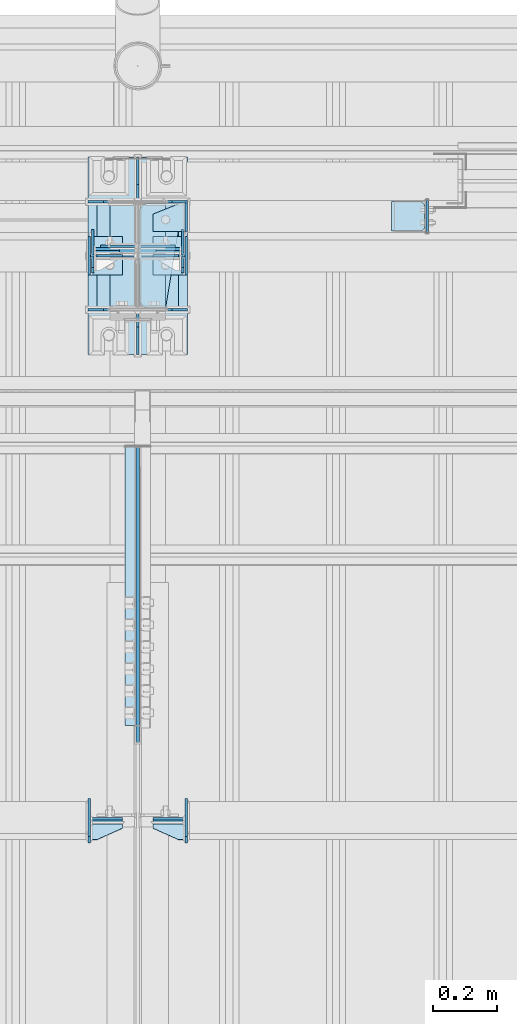
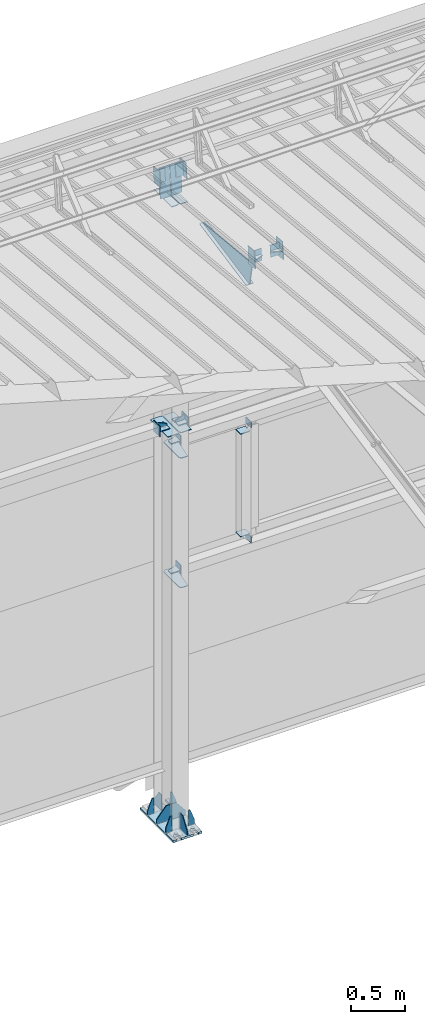
# One storey, part 138 of 709: 43 plates, 4 openings, 11 elements without a shape of their own.
"""IFC4 building model written with IfcOpenShell, lengths in millimetres."""

import ifcopenshell
import ifcopenshell.guid

model = None  # the IFC model being written
_history = None  # IfcOwnerHistory: only IFC2X3 demands one
_inside = {}  # id of a spatial element -> (the spatial element, [elements in it])
_under = {}  # id of a project, library or spatial element -> (it, [spatial elements below it])
_declared = {}  # id of a project -> (the project, [libraries it declares])
_typed = {}  # id of a type object -> (the type object, [elements of that type])
_made_of = {}  # id of a material, layer set ... -> (it, [elements and type objects made of it])


def new_model(schema):
    """Start an empty IFC model of exactly this schema.

    Asked for "IFC4X3", IfcOpenShell would pick the latest addendum, in which some entities
    have other attributes; the version numbers below select the first issue.
    IFC2X3 requires an IfcOwnerHistory on every rooted entity: one is made here for all.
    """
    global model, _history
    if schema == "IFC4X3":
        model = ifcopenshell.file(schema_version=(4, 3, 0, 0))
    else:
        model = ifcopenshell.file(schema=schema)
    _inside.clear()
    _under.clear()
    _declared.clear()
    _typed.clear()
    _made_of.clear()
    _history = None
    if model.schema == "IFC2X3":
        org = make("IfcOrganization", Name="unknown")
        user = make(
            "IfcPersonAndOrganization",
            ThePerson=make("IfcPerson", FamilyName="unknown"),
            TheOrganization=org,
        )
        app = make(
            "IfcApplication",
            ApplicationDeveloper=org,
            Version="unknown",
            ApplicationFullName="unknown",
            ApplicationIdentifier="unknown",
        )
        _history = make(
            "IfcOwnerHistory",
            OwningUser=user,
            OwningApplication=app,
            ChangeAction="ADDED",
            CreationDate=0,
        )
    return model


def make(cls, **values):
    """One entity of the class cls with the attributes given. An attribute that is None is left unset."""
    return model.create_entity(
        cls, **{name: value for name, value in values.items() if value is not None}
    )


def rooted(cls, **values):
    """An entity with a GlobalId (a new one), such as an element, a storey or a relation."""
    return make(cls, GlobalId=ifcopenshell.guid.new(), OwnerHistory=_history, **values)


def si_unit(unit_type, name, prefix=None):
    """IfcSIUnit, for example si_unit("LENGTHUNIT", "METRE", prefix="MILLI")."""
    return make("IfcSIUnit", UnitType=unit_type, Prefix=prefix, Name=name)


def assignment(units):
    """IfcUnitAssignment: the units of a project."""
    return None if units is None else make("IfcUnitAssignment", Units=units)


def point(xyz):
    """IfcCartesianPoint."""
    return None if xyz is None else make("IfcCartesianPoint", Coordinates=xyz)


def direction(xyz):
    """IfcDirection."""
    return None if xyz is None else make("IfcDirection", DirectionRatios=xyz)


def frame(location, z_axis=None, x_axis=None):
    """IfcAxis2Placement3D, a coordinate frame: its origin and axes. An axis left out is left unset."""
    return make(
        "IfcAxis2Placement3D",
        Location=point(location),
        Axis=direction(z_axis),
        RefDirection=direction(x_axis),
    )


def origin_with_axes():
    """The frame at (0, 0, 0) with the z axis (0, 0, 1) and the x axis (1, 0, 0) written out."""
    return frame((0.0, 0.0, 0.0), z_axis=(0.0, 0.0, 1.0), x_axis=(1.0, 0.0, 0.0))


def place(relative_to, where):
    """IfcLocalPlacement: puts the frame where relative to a parent placement (None: the world)."""
    return make(
        "IfcLocalPlacement", PlacementRelTo=relative_to, RelativePlacement=where
    )


def context(
    kind, dimensions, precision=None, world=None, true_north=None, identifier=None
):
    """IfcGeometricRepresentationContext, for example the 3D "Model" context."""
    return make(
        "IfcGeometricRepresentationContext",
        ContextIdentifier=identifier,
        ContextType=kind,
        CoordinateSpaceDimension=dimensions,
        Precision=precision,
        WorldCoordinateSystem=world,
        TrueNorth=true_north,
    )


def subcontext(parent, identifier, kind, view, scale=None):
    """IfcGeometricRepresentationSubContext, for example "Body" below "Model"."""
    return make(
        "IfcGeometricRepresentationSubContext",
        ContextIdentifier=identifier,
        ContextType=kind,
        ParentContext=parent,
        TargetScale=scale,
        TargetView=view,
    )


def project(units=None, contexts=None):
    """IfcProject with its units and contexts."""
    return rooted(
        "IfcProject",
        Name="project",
        RepresentationContexts=contexts,
        UnitsInContext=assignment(units),
    )


def spatial(cls, under=None, at=None, **own):
    """A site, building, storey or space (cls), placed at a placement, below another one or the project."""
    s = rooted(cls, ObjectPlacement=at, **own)
    if under is not None:
        _under.setdefault(under.id(), (under, []))[1].append(s)
    return s


def point_list(points):
    """IfcCartesianPointList2D or 3D."""
    cls = (
        "IfcCartesianPointList2D" if len(points[0]) == 2 else "IfcCartesianPointList3D"
    )
    return make(cls, CoordList=points)


def line(*indices):
    """IfcLineIndex: a straight run through numbered points of an indexed curve."""
    return model.create_entity("IfcLineIndex", indices)


def arc(*indices):
    """IfcArcIndex: an arc through three numbered points of an indexed curve."""
    return model.create_entity("IfcArcIndex", indices)


def indexed_curve(points, segments=None, self_intersect=None):
    """IfcIndexedPolyCurve: lines and arcs through numbered points (the first is 1)."""
    return make(
        "IfcIndexedPolyCurve",
        Points=point_list(points),
        Segments=segments,
        SelfIntersect=self_intersect,
    )


def outline(outer, holes=None, kind="AREA"):
    """IfcArbitraryClosedProfileDef: a profile drawn as a closed curve; with holes, ...WithVoids."""
    if holes is None:
        return make("IfcArbitraryClosedProfileDef", ProfileType=kind, OuterCurve=outer)
    return make(
        "IfcArbitraryProfileDefWithVoids",
        ProfileType=kind,
        OuterCurve=outer,
        InnerCurves=holes,
    )


def extrude(swept, where, along, depth):
    """IfcExtrudedAreaSolid: the profile swept, set in the frame where, extruded along a direction by depth."""
    return make(
        "IfcExtrudedAreaSolid",
        SweptArea=swept,
        Position=where,
        ExtrudedDirection=direction(along),
        Depth=depth,
    )


def shape(context_of_items, identifier, shape_type, items):
    """IfcShapeRepresentation: the items that make up one representation, for example the "Body"."""
    return make(
        "IfcShapeRepresentation",
        ContextOfItems=context_of_items,
        RepresentationIdentifier=identifier,
        RepresentationType=shape_type,
        Items=items,
    )


def material(Name=None, Category=None):
    """IfcMaterial."""
    return make("IfcMaterial", Name=Name, Category=Category)


def made_of(thing, what):
    """Note that an element or type object is made of a material, layer set ...; save() writes the relation."""
    if what is not None:
        _made_of.setdefault(what.id(), (what, []))[1].append(thing)
    return thing


def element(
    cls,
    number,
    at=None,
    inside=None,
    cuts=None,
    type_object=None,
    material=None,
    context=None,
    identifier="Body",
    shape_type=None,
    held_by="IfcProductDefinitionShape",
    body=None,
    shapes=None,
    **own,
):
    """One element of the class cls, such as IfcWall. Its Tag is "e" and its number.

    at: its placement. inside: the storey or other place that contains it. cuts: it is an
    opening in that element (IfcRelVoidsElement). A single representation is given by context,
    identifier, shape_type and body (its items); several are given by shapes. held_by: the class
    of the entity that holds the representations. save() writes the other relations.
    """
    e = rooted(cls, Tag="e%d" % number, ObjectPlacement=at, **own)
    if body is not None:
        shapes = [shape(context, identifier, shape_type, body)]
    if shapes is not None:
        e.Representation = make(held_by, Representations=shapes)
    if inside is not None:
        _inside.setdefault(inside.id(), (inside, []))[1].append(e)
    if cuts is not None:
        rooted(
            "IfcRelVoidsElement", RelatingBuildingElement=cuts, RelatedOpeningElement=e
        )
    if type_object is not None:
        _typed.setdefault(type_object.id(), (type_object, []))[1].append(e)
    return made_of(e, material)


def aggregate(whole, parts):
    """IfcRelAggregates: a whole, such as a stair, and the parts it consists of."""
    return rooted("IfcRelAggregates", RelatingObject=whole, RelatedObjects=parts)


def save(model, path):
    """Write the relations noted so far, then the file.

    IfcRelAggregates (storeys below a building ...), IfcRelContainedInSpatialStructure (elements
    in a storey), IfcRelDefinesByType, IfcRelAssociatesMaterial and IfcRelDeclares: one each for
    every whole, place, type object, material and project.
    """
    for whole, parts in _under.values():
        aggregate(whole, parts)
    for where, things in _inside.values():
        rooted(
            "IfcRelContainedInSpatialStructure",
            RelatedElements=things,
            RelatingStructure=where,
        )
    for kind, things in _typed.values():
        rooted("IfcRelDefinesByType", RelatedObjects=things, RelatingType=kind)
    for what, things in _made_of.values():
        rooted("IfcRelAssociatesMaterial", RelatedObjects=things, RelatingMaterial=what)
    for by, libraries in _declared.values():
        rooted("IfcRelDeclares", RelatingContext=by, RelatedDefinitions=libraries)
    model.write(path)


model = new_model("IFC4")

# Units and contexts
model_context = context("Model", 3, precision=0.2, world=origin_with_axes(), true_north=direction((0.0, 1.0)))
body_context = subcontext(model_context, "Body", "Model", "MODEL_VIEW")
ifc_project = project(units=[si_unit("LENGTHUNIT", "METRE", prefix="MILLI"), si_unit("AREAUNIT", "SQUARE_METRE"), si_unit("VOLUMEUNIT", "CUBIC_METRE"), si_unit("MASSUNIT", "GRAM", prefix="KILO"), si_unit("TIMEUNIT", "SECOND"), si_unit("PLANEANGLEUNIT", "RADIAN"), si_unit("SOLIDANGLEUNIT", "STERADIAN"), si_unit("THERMODYNAMICTEMPERATUREUNIT", "DEGREE_CELSIUS"), si_unit("LUMINOUSINTENSITYUNIT", "LUMEN")], contexts=[model_context])

# Site, building, storey
site_placement = place(None, origin_with_axes())
site = spatial("IfcSite", under=ifc_project, at=site_placement, CompositionType="ELEMENT")
building_placement = place(site_placement, origin_with_axes())
building = spatial("IfcBuilding", under=site, at=building_placement, Name="Undefined", CompositionType="ELEMENT")
storey_placement = place(building_placement, origin_with_axes())
storey = spatial("IfcBuildingStorey", under=building, at=storey_placement, Name="Undefined", CompositionType="ELEMENT", Elevation=0.0)

# Assembly, plates, voiding features
assembly_1_placement = place(storey_placement, frame((16000.0, 21827.0, -200.0), z_axis=(-1.0, 0.0, 0.0), x_axis=(0.0, 0.0, 1.0)))
assembly_1 = element("IfcElementAssembly", 1, at=assembly_1_placement, inside=storey)
ifc_material = material(Name="C355-6", Category="STEEL")
plate_1_placement = place(assembly_1_placement, frame((7434.21546, 30.02526, 3.0), z_axis=(0.099503719, -0.9950371902, 0.0), x_axis=(0.0, 0.0, 1.0)))
plate_1 = element("IfcPlate", 2, at=plate_1_placement, material=ifc_material, ObjectType="595", context=body_context, shape_type="SolidModel", body=[
    extrude(outline(indexed_curve([(0.0, 0.0), (114.0, 0.0), (114.0, 332.53554), (0.0, 332.53554)], segments=[line(1, 2, 3, 4, 1)])), frame((0.0, 0.0, 4.0), z_axis=(0.0, 0.0, 1.0), x_axis=(1.0, 0.0, 0.0)), (0.0, 0.0, -1.0), 8.0),
])
plate_2_placement = place(assembly_1_placement, frame((7097.93718, 163.0, 87.0), z_axis=(-1.0, 0.0, 0.0), x_axis=(0.0, 0.0, -1.0)))
plate_2 = element("IfcPlate", 3, at=plate_2_placement, material=ifc_material, ObjectType="461", context=body_context, shape_type="SolidModel", body=[
    extrude(outline(indexed_curve([(0.0, 0.0), (68.0, 0.0), (83.0, 15.0), (83.0, 311.0), (68.0, 326.0), (0.0, 326.0)], segments=[line(1, 2, 3, 4, 5, 6, 1)])), frame((0.0, 0.0, 4.0), z_axis=(0.0, 0.0, 1.0), x_axis=(1.0, 0.0, 0.0)), (0.0, 0.0, -1.0), 8.0),
])
plate_3_placement = place(assembly_1_placement, frame((7097.93718, -163.0, -87.0), z_axis=(-1.0, 0.0, 0.0), x_axis=(0.0, 0.0, 1.0)))
plate_3 = element("IfcPlate", 4, at=plate_3_placement, material=ifc_material, ObjectType="461", context=body_context, shape_type="SolidModel", body=[
    extrude(outline(indexed_curve([(0.0, 0.0), (68.0, 0.0), (83.0, 15.0), (83.0, 311.0), (68.0, 326.0), (0.0, 326.0)], segments=[line(1, 2, 3, 4, 5, 6, 1)])), frame((0.0, 0.0, 4.0), z_axis=(0.0, 0.0, 1.0), x_axis=(1.0, 0.0, 0.0)), (0.0, 0.0, -1.0), 8.0),
])
plate_4_placement = place(assembly_1_placement, frame((25.0, 173.0, 0.0), z_axis=(0.0, 0.0, -1.0), x_axis=(0.0, 1.0, 0.0)))
plate_4 = element("IfcPlate", 5, at=plate_4_placement, material=ifc_material, ObjectType="418", context=body_context, shape_type="SolidModel", body=[
    extrude(outline(indexed_curve([(0.0, 0.0), (135.0, 0.0), (135.0, 50.0), (50.0, 175.0), (0.0, 175.0)], segments=[line(1, 2, 3, 4, 5, 1)])), frame((0.0, 0.0, 4.0), z_axis=(0.0, 0.0, 1.0), x_axis=(1.0, 0.0, 0.0)), (0.0, 0.0, -1.0), 8.0),
])
plate_5_placement = place(assembly_1_placement, frame((25.0, 0.0, 3.0), z_axis=(0.0, 1.0, 0.0), x_axis=(0.0, 0.0, 1.0)))
plate_5 = element("IfcPlate", 6, at=plate_5_placement, material=ifc_material, ObjectType="417", context=body_context, shape_type="SolidModel", body=[
    extrude(outline(indexed_curve([(0.0, 0.0), (152.0, 0.0), (152.0, 50.0), (50.0, 175.0), (0.0, 175.0)], segments=[line(1, 2, 3, 4, 5, 1)])), frame((0.0, 0.0, 4.0), z_axis=(0.0, 0.0, 1.0), x_axis=(1.0, 0.0, 0.0)), (0.0, 0.0, -1.0), 8.0),
])
plate_6_placement = place(assembly_1_placement, frame((25.0, 0.0, -3.0), z_axis=(0.0, -1.0, 0.0), x_axis=(0.0, 0.0, -1.0)))
plate_6 = element("IfcPlate", 7, at=plate_6_placement, material=ifc_material, ObjectType="417", context=body_context, shape_type="SolidModel", body=[
    extrude(outline(indexed_curve([(0.0, 0.0), (152.0, 0.0), (152.0, 50.0), (50.0, 175.0), (0.0, 175.0)], segments=[line(1, 2, 3, 4, 5, 1)])), frame((0.0, 0.0, 4.0), z_axis=(0.0, 0.0, 1.0), x_axis=(1.0, 0.0, 0.0)), (0.0, 0.0, -1.0), 8.0),
])
plate_7_placement = place(assembly_1_placement, frame((25.0, -173.0, 0.0), z_axis=(0.0, 0.0, 1.0), x_axis=(0.0, -1.0, 0.0)))
plate_7 = element("IfcPlate", 8, at=plate_7_placement, material=ifc_material, ObjectType="418", context=body_context, shape_type="SolidModel", body=[
    extrude(outline(indexed_curve([(0.0, 0.0), (135.0, 0.0), (135.0, 50.0), (50.0, 175.0), (0.0, 175.0)], segments=[line(1, 2, 3, 4, 5, 1)])), frame((0.0, 0.0, 4.0), z_axis=(0.0, 0.0, 1.0), x_axis=(1.0, 0.0, 0.0)), (0.0, 0.0, -1.0), 8.0),
])
plate_8_placement = place(assembly_1_placement, frame((25.0, -168.5, -87.0), z_axis=(0.0, -1.0, 0.0), x_axis=(0.0, 0.0, -1.0)))
plate_8 = element("IfcPlate", 9, at=plate_8_placement, material=ifc_material, ObjectType="419", context=body_context, shape_type="SolidModel", body=[
    extrude(outline(indexed_curve([(0.0, 0.0), (68.0, 0.0), (68.0, 50.0), (20.0, 175.0), (0.0, 175.0)], segments=[line(1, 2, 3, 4, 5, 1)])), frame((0.0, 0.0, 4.0), z_axis=(0.0, 0.0, 1.0), x_axis=(1.0, 0.0, 0.0)), (0.0, 0.0, -1.0), 8.0),
])
plate_9_placement = place(assembly_1_placement, frame((25.0, 168.5, 87.0), z_axis=(0.0, 1.0, 0.0), x_axis=(0.0, 0.0, 1.0)))
plate_9 = element("IfcPlate", 10, at=plate_9_placement, material=ifc_material, ObjectType="419", context=body_context, shape_type="SolidModel", body=[
    extrude(outline(indexed_curve([(0.0, 0.0), (68.0, 0.0), (68.0, 50.0), (20.0, 175.0), (0.0, 175.0)], segments=[line(1, 2, 3, 4, 5, 1)])), frame((0.0, 0.0, 4.0), z_axis=(0.0, 0.0, 1.0), x_axis=(1.0, 0.0, 0.0)), (0.0, 0.0, -1.0), 8.0),
])
plate_10_placement = place(assembly_1_placement, frame((25.0, -168.5, 87.0), z_axis=(0.0, 1.0, 0.0), x_axis=(0.0, 0.0, 1.0)))
plate_10 = element("IfcPlate", 11, at=plate_10_placement, material=ifc_material, ObjectType="419", context=body_context, shape_type="SolidModel", body=[
    extrude(outline(indexed_curve([(0.0, 0.0), (68.0, 0.0), (68.0, 50.0), (20.0, 175.0), (0.0, 175.0)], segments=[line(1, 2, 3, 4, 5, 1)])), frame((0.0, 0.0, 4.0), z_axis=(0.0, 0.0, 1.0), x_axis=(1.0, 0.0, 0.0)), (0.0, 0.0, -1.0), 8.0),
])
plate_11_placement = place(assembly_1_placement, frame((25.0, 168.5, -87.0), z_axis=(0.0, -1.0, 0.0), x_axis=(0.0, 0.0, -1.0)))
plate_11 = element("IfcPlate", 12, at=plate_11_placement, material=ifc_material, ObjectType="419", context=body_context, shape_type="SolidModel", body=[
    extrude(outline(indexed_curve([(0.0, 0.0), (68.0, 0.0), (68.0, 50.0), (20.0, 175.0), (0.0, 175.0)], segments=[line(1, 2, 3, 4, 5, 1)])), frame((0.0, 0.0, 4.0), z_axis=(0.0, 0.0, 1.0), x_axis=(1.0, 0.0, 0.0)), (0.0, 0.0, -1.0), 8.0),
])
plate_12_placement = place(assembly_1_placement, frame((12.5, -308.0, 155.0), z_axis=(1.0, 0.0, 0.0), x_axis=(0.0, 0.0, -1.0)))
plate_12 = element("IfcPlate", 13, at=plate_12_placement, material=ifc_material, ObjectType="416", context=body_context, shape_type="SolidModel", body=[
    extrude(outline(indexed_curve([(0.0, 0.0), (310.0, 0.0), (310.0, 616.0), (0.0, 616.0)], segments=[line(1, 2, 3, 4, 1)])), frame((0.0, 0.0, 12.5), z_axis=(0.0, 0.0, 1.0), x_axis=(1.0, 0.0, 0.0)), (0.0, 0.0, -1.0), 25.0),
])
voiding_feature_1_placement = place(plate_12_placement, frame((40.0, 616.0, 0.0), z_axis=(0.0, 0.0, -1.0), x_axis=(1.0, 0.0, 0.0)))
element("IfcVoidingFeature", 14, at=voiding_feature_1_placement, cuts=plate_12, PredefinedType="HOLE", context=body_context, shape_type="SolidModel", body=[
    extrude(outline(indexed_curve([(0.0, 0.0), (50.0, 0.0), (50.0, 60.0), (42.67767, 77.67767), (25.0, 85.0), (25.0, 85.0), (7.32233, 77.67767), (0.0, 60.0)], segments=[line(1, 2, 3), arc(3, 4, 5), line(5, 6), arc(6, 7, 8), line(8, 1)])), frame((0.0, 0.0, 12.5), z_axis=(0.0, 0.0, 1.0), x_axis=(1.0, 0.0, 0.0)), (0.0, 0.0, -1.0), 25.0),
])
voiding_feature_2_placement = place(plate_12_placement, frame((40.0, 0.0, 0.0), z_axis=(0.0, 0.0, 1.0), x_axis=(1.0, 0.0, 0.0)))
element("IfcVoidingFeature", 15, at=voiding_feature_2_placement, cuts=plate_12, PredefinedType="HOLE", context=body_context, shape_type="SolidModel", body=[
    extrude(outline(indexed_curve([(0.0, 0.0), (50.0, 0.0), (50.0, 60.0), (42.67767, 77.67767), (25.0, 85.0), (25.0, 85.0), (7.32233, 77.67767), (0.0, 60.0)], segments=[line(1, 2, 3), arc(3, 4, 5), line(5, 6), arc(6, 7, 8), line(8, 1)])), frame((0.0, 0.0, 12.5), z_axis=(0.0, 0.0, 1.0), x_axis=(1.0, 0.0, 0.0)), (0.0, 0.0, -1.0), 25.0),
])
voiding_feature_3_placement = place(plate_12_placement, frame((270.0, 616.0, 0.0), z_axis=(0.0, 0.0, 1.0), x_axis=(-1.0, 0.0, 0.0)))
element("IfcVoidingFeature", 16, at=voiding_feature_3_placement, cuts=plate_12, PredefinedType="HOLE", context=body_context, shape_type="SolidModel", body=[
    extrude(outline(indexed_curve([(0.0, 0.0), (50.0, 0.0), (50.0, 60.0), (42.67767, 77.67767), (25.0, 85.0), (25.0, 85.0), (7.32233, 77.67767), (0.0, 60.0)], segments=[line(1, 2, 3), arc(3, 4, 5), line(5, 6), arc(6, 7, 8), line(8, 1)])), frame((0.0, 0.0, 12.5), z_axis=(0.0, 0.0, 1.0), x_axis=(1.0, 0.0, 0.0)), (0.0, 0.0, -1.0), 25.0),
])
voiding_feature_4_placement = place(plate_12_placement, frame((270.0, 0.0, 0.0), z_axis=(0.0, 0.0, -1.0), x_axis=(-1.0, 0.0, 0.0)))
element("IfcVoidingFeature", 17, at=voiding_feature_4_placement, cuts=plate_12, PredefinedType="HOLE", context=body_context, shape_type="SolidModel", body=[
    extrude(outline(indexed_curve([(0.0, 0.0), (50.0, 0.0), (50.0, 60.0), (42.67767, 77.67767), (25.0, 85.0), (25.0, 85.0), (7.32233, 77.67767), (0.0, 60.0)], segments=[line(1, 2, 3), arc(3, 4, 5), line(5, 6), arc(6, 7, 8), line(8, 1)])), frame((0.0, 0.0, 12.5), z_axis=(0.0, 0.0, 1.0), x_axis=(1.0, 0.0, 0.0)), (0.0, 0.0, -1.0), 25.0),
])
plate_13_placement = place(assembly_1_placement, frame((2742.0, -163.0, -4.0), z_axis=(1.0, 0.0, 0.0), x_axis=(0.0, 0.0, -1.0)))
plate_13 = element("IfcPlate", 18, at=plate_13_placement, material=ifc_material, ObjectType="543", context=body_context, shape_type="SolidModel", body=[
    extrude(outline(indexed_curve([(0.0, 20.0), (20.0, 0.0), (83.0, 0.0), (123.0, 240.0), (123.0, 326.0), (20.0, 326.0), (0.0, 306.0)], segments=[line(1, 2, 3, 4, 5, 6, 7, 1)])), frame((0.0, 0.0, 4.0), z_axis=(0.0, 0.0, 1.0), x_axis=(1.0, 0.0, 0.0)), (0.0, 0.0, -1.0), 8.0),
])
plate_14_placement = place(assembly_1_placement, frame((4212.0, -163.0, -4.0), z_axis=(1.0, 0.0, 0.0), x_axis=(0.0, 0.0, -1.0)))
plate_14 = element("IfcPlate", 19, at=plate_14_placement, material=ifc_material, ObjectType="543", context=body_context, shape_type="SolidModel", body=[
    extrude(outline(indexed_curve([(0.0, 20.0), (20.0, 0.0), (83.0, 0.0), (123.0, 240.0), (123.0, 326.0), (20.0, 326.0), (0.0, 306.0)], segments=[line(1, 2, 3, 4, 5, 6, 7, 1)])), frame((0.0, 0.0, 4.0), z_axis=(0.0, 0.0, 1.0), x_axis=(1.0, 0.0, 0.0)), (0.0, 0.0, -1.0), 8.0),
])
plate_15_placement = place(assembly_1_placement, frame((4502.0, -163.0, -127.0), z_axis=(-1.0, 0.0, 0.0), x_axis=(0.0, 0.0, 1.0)))
plate_15 = element("IfcPlate", 20, at=plate_15_placement, material=ifc_material, ObjectType="547", context=body_context, shape_type="SolidModel", body=[
    extrude(outline(indexed_curve([(0.0, 0.0), (108.0, 0.0), (123.0, 15.0), (123.0, 311.0), (108.0, 326.0), (0.0, 326.0)], segments=[line(1, 2, 3, 4, 5, 6, 1)])), frame((0.0, 0.0, 4.0), z_axis=(0.0, 0.0, 1.0), x_axis=(1.0, 0.0, 0.0)), (0.0, 0.0, -1.0), 8.0),
])
plate_16_placement = place(assembly_1_placement, frame((4502.0, 163.0, 127.0), z_axis=(-1.0, 0.0, 0.0), x_axis=(0.0, 0.0, -1.0)))
plate_16 = element("IfcPlate", 21, at=plate_16_placement, material=ifc_material, ObjectType="547", context=body_context, shape_type="SolidModel", body=[
    extrude(outline(indexed_curve([(0.0, 0.0), (108.0, 0.0), (123.0, 15.0), (123.0, 311.0), (108.0, 326.0), (0.0, 326.0)], segments=[line(1, 2, 3, 4, 5, 6, 1)])), frame((0.0, 0.0, 4.0), z_axis=(0.0, 0.0, 1.0), x_axis=(1.0, 0.0, 0.0)), (0.0, 0.0, -1.0), 8.0),
])
plate_17_placement = place(assembly_1_placement, frame((7434.21546, 30.02526, -3.0), z_axis=(-0.099503719, 0.9950371902, 0.0), x_axis=(0.0, 0.0, -1.0)))
plate_17 = element("IfcPlate", 22, at=plate_17_placement, material=ifc_material, ObjectType="595", context=body_context, shape_type="SolidModel", body=[
    extrude(outline(indexed_curve([(0.0, 0.0), (114.0, 0.0), (114.0, 333.33554), (0.0, 333.33554)], segments=[line(1, 2, 3, 4, 1)])), frame((0.0, 0.0, 4.0), z_axis=(0.0, 0.0, 1.0), x_axis=(1.0, 0.0, 0.0)), (0.0, 0.0, -1.0), 8.0),
])
aggregate(assembly_1, [plate_1, plate_2, plate_3, plate_4, plate_5, plate_6, plate_7, plate_8, plate_9, plate_10, plate_11, plate_12, plate_13, plate_14, plate_15, plate_16, plate_17])

# Assembly, plates
assembly_2_placement = place(storey_placement, frame((16000.0, 21654.0, 7089.70002), z_axis=(-1.0, 0.0, 0.0), x_axis=(0.0, -0.9950371902, 0.099503719)))
assembly_2 = element("IfcElementAssembly", 23, at=assembly_2_placement, inside=storey)
plate_18_placement = place(assembly_2_placement, frame((1255.8048, -434.94249, -40.0), z_axis=(0.2927142719, 0.9561999556, 0.0), x_axis=(-0.9561999556, 0.2927142719, 0.0)))
plate_18 = element("IfcPlate", 24, at=plate_18_placement, material=ifc_material, ObjectType="450", context=body_context, shape_type="SolidModel", body=[
    extrude(outline(indexed_curve([(0.0, 0.0), (887.65935, 0.0), (887.65935, 80.0), (0.0, 80.0)], segments=[line(1, 2, 3, 4, 1)])), frame((0.0, 0.0, 4.0), z_axis=(0.0, 0.0, 1.0), x_axis=(1.0, 0.0, 0.0)), (0.0, 0.0, -1.0), 8.0),
])
plate_19_placement = place(assembly_2_placement, frame((1336.51563, -171.28713, 0.0), z_axis=(0.0, 0.0, 1.0), x_axis=(-1.0, 0.0, 0.0)))
plate_19 = element("IfcPlate", 25, at=plate_19_placement, material=ifc_material, ObjectType="449", context=body_context, shape_type="SolidModel", body=[
    extrude(outline(indexed_curve([(0.0, 0.0), (928.3198, 0.0), (79.53997, 259.83056)], segments=[line(1, 2, 3, 1)])), frame((0.0, 0.0, 6.0), z_axis=(0.0, 0.0, 1.0), x_axis=(1.0, 0.0, 0.0)), (0.0, 0.0, -1.0), 12.0),
])
aggregate(assembly_2, [plate_18, plate_19])

assembly_3_placement = place(storey_placement, frame((22000.0, 21950.0, 2550.0), z_axis=(0.0, 0.0, -1.0), x_axis=(-1.0, 0.0, 0.0)))
assembly_3 = element("IfcElementAssembly", 26, at=assembly_3_placement, inside=storey)
plate_20_placement = place(assembly_3_placement, frame((5849.0, 47.0, -60.0), z_axis=(-1.0, 0.0, 0.0), x_axis=(0.0, -1.0, 0.0)))
plate_20 = element("IfcPlate", 27, at=plate_20_placement, material=ifc_material, ObjectType="501", context=body_context, shape_type="SolidModel", body=[
    extrude(outline(indexed_curve([(0.0, 0.0), (94.0, 0.0), (94.0, 120.0), (0.0, 120.0)], segments=[line(1, 2, 3, 4, 1)])), frame((0.0, 0.0, 4.0), z_axis=(0.0, 0.0, 1.0), x_axis=(1.0, 0.0, 0.0)), (0.0, 0.0, -1.0), 8.0),
])
plate_21_placement = place(assembly_3_placement, frame((5853.0, 47.0, 0.0), z_axis=(0.0, 0.0, 1.0), x_axis=(0.0, -1.0, 0.0)))
plate_21 = element("IfcPlate", 28, at=plate_21_placement, material=ifc_material, ObjectType="502", context=body_context, shape_type="SolidModel", body=[
    extrude(outline(indexed_curve([(0.0, 0.0), (94.0, 0.0), (94.0, 100.0), (40.0, 100.0), (0.0, 0.0)], segments=[line(1, 2, 3, 4, 5, 1)])), frame((0.0, 0.0, 4.0), z_axis=(0.0, 0.0, 1.0), x_axis=(1.0, 0.0, 0.0)), (0.0, 0.0, -1.0), 8.0),
])
plate_22_placement = place(assembly_3_placement, frame((5096.0, 50.0, -50.0), z_axis=(-1.0, 0.0, 0.0), x_axis=(0.0, 0.0, -1.0)))
plate_22 = element("IfcPlate", 29, at=plate_22_placement, material=ifc_material, ObjectType="509", context=body_context, shape_type="SolidModel", body=[
    extrude(outline(indexed_curve([(0.0, 0.0), (65.0, 0.0), (65.0, 100.0), (0.0, 100.0)], segments=[line(1, 2, 3, 4, 1)])), frame((0.0, 0.0, 4.0), z_axis=(0.0, 0.0, 1.0), x_axis=(1.0, 0.0, 0.0)), (0.0, 0.0, -1.0), 8.0),
])
aggregate(assembly_3, [plate_20, plate_21, plate_22])

assembly_4_placement = place(storey_placement, frame((22000.0, 21950.0, 4020.0), z_axis=(0.0, 0.0, -1.0), x_axis=(-1.0, 0.0, 0.0)))
assembly_4 = element("IfcElementAssembly", 30, at=assembly_4_placement, inside=storey)
plate_23_placement = place(assembly_4_placement, frame((5849.0, 47.0, -60.0), z_axis=(-1.0, 0.0, 0.0), x_axis=(0.0, -1.0, 0.0)))
plate_23 = element("IfcPlate", 31, at=plate_23_placement, material=ifc_material, ObjectType="501", context=body_context, shape_type="SolidModel", body=[
    extrude(outline(indexed_curve([(0.0, 0.0), (94.0, 0.0), (94.0, 120.0), (0.0, 120.0)], segments=[line(1, 2, 3, 4, 1)])), frame((0.0, 0.0, 4.0), z_axis=(0.0, 0.0, 1.0), x_axis=(1.0, 0.0, 0.0)), (0.0, 0.0, -1.0), 8.0),
])
plate_24_placement = place(assembly_4_placement, frame((5853.0, 47.0, 0.0), z_axis=(0.0, 0.0, 1.0), x_axis=(0.0, -1.0, 0.0)))
plate_24 = element("IfcPlate", 32, at=plate_24_placement, material=ifc_material, ObjectType="502", context=body_context, shape_type="SolidModel", body=[
    extrude(outline(indexed_curve([(0.0, 0.0), (94.0, 0.0), (94.0, 100.0), (40.0, 100.0), (0.0, 0.0)], segments=[line(1, 2, 3, 4, 5, 1)])), frame((0.0, 0.0, 4.0), z_axis=(0.0, 0.0, 1.0), x_axis=(1.0, 0.0, 0.0)), (0.0, 0.0, -1.0), 8.0),
])
plate_25_placement = place(assembly_4_placement, frame((5096.0, -50.0, 50.0), z_axis=(-1.0, 0.0, 0.0), x_axis=(0.0, 0.0, 1.0)))
plate_25 = element("IfcPlate", 33, at=plate_25_placement, material=ifc_material, ObjectType="509", context=body_context, shape_type="SolidModel", body=[
    extrude(outline(indexed_curve([(0.0, 0.0), (65.0, 0.0), (65.0, 100.0), (0.0, 100.0)], segments=[line(1, 2, 3, 4, 1)])), frame((0.0, 0.0, 4.0), z_axis=(0.0, 0.0, 1.0), x_axis=(1.0, 0.0, 0.0)), (0.0, 0.0, -1.0), 8.0),
])
aggregate(assembly_4, [plate_23, plate_24, plate_25])

assembly_5_placement = place(storey_placement, frame((16850.0, 21950.0, 2600.0), z_axis=(-1.0, 0.0, 0.0), x_axis=(0.0, 0.0, 1.0)))
assembly_5 = element("IfcElementAssembly", 34, at=assembly_5_placement, inside=storey)
plate_26_placement = place(assembly_5_placement, frame((103.0, 46.0, -46.0), z_axis=(-1.0, 0.0, 0.0), x_axis=(0.0, -1.0, 0.0)))
plate_26 = element("IfcPlate", 35, at=plate_26_placement, material=ifc_material, ObjectType="510", context=body_context, shape_type="SolidModel", body=[
    extrude(outline(indexed_curve([(0.0, 10.0), (10.0, 0.0), (82.0, 0.0), (92.0, 10.0), (92.0, 104.0), (0.0, 104.0)], segments=[line(1, 2, 3, 4, 5, 6, 1)])), frame((0.0, 0.0, 4.0), z_axis=(0.0, 0.0, 1.0), x_axis=(1.0, 0.0, 0.0)), (0.0, 0.0, -1.0), 8.0),
])
plate_27_placement = place(assembly_5_placement, frame((1267.0, -46.0, -46.0), z_axis=(1.0, 0.0, 0.0), x_axis=(0.0, 1.0, 0.0)))
plate_27 = element("IfcPlate", 36, at=plate_27_placement, material=ifc_material, ObjectType="510", context=body_context, shape_type="SolidModel", body=[
    extrude(outline(indexed_curve([(0.0, 10.0), (10.0, 0.0), (82.0, 0.0), (92.0, 10.0), (92.0, 104.0), (0.0, 104.0)], segments=[line(1, 2, 3, 4, 5, 6, 1)])), frame((0.0, 0.0, 4.0), z_axis=(0.0, 0.0, 1.0), x_axis=(1.0, 0.0, 0.0)), (0.0, 0.0, -1.0), 8.0),
])
aggregate(assembly_5, [plate_26, plate_27])

assembly_6_placement = place(storey_placement, frame((22000.0, 21827.0, 4310.0), z_axis=(0.0, 0.0, -1.0), x_axis=(-1.0, 0.0, 0.0)))
assembly_6 = element("IfcElementAssembly", 37, at=assembly_6_placement, inside=storey)
plate_28_placement = place(assembly_6_placement, frame((5953.0, 0.0, -60.0), z_axis=(0.0, -1.0, 0.0), x_axis=(0.0, 0.0, 1.0)))
plate_28 = element("IfcPlate", 38, at=plate_28_placement, material=ifc_material, ObjectType="508", context=body_context, shape_type="SolidModel", body=[
    extrude(outline(indexed_curve([(0.0, 80.0), (36.0, 0.0), (56.0, 0.0), (56.0, 90.0), (46.0, 100.0), (0.0, 100.0)], segments=[line(1, 2, 3, 4, 5, 6, 1)])), frame((0.0, 0.0, 4.0), z_axis=(0.0, 0.0, 1.0), x_axis=(1.0, 0.0, 0.0)), (0.0, 0.0, -1.0), 8.0),
])
plate_29_placement = place(assembly_6_placement, frame((5953.0, -60.0, 0.0), z_axis=(0.0, 0.0, 1.0), x_axis=(0.0, 1.0, 0.0)))
plate_29 = element("IfcPlate", 39, at=plate_29_placement, material=ifc_material, ObjectType="507", context=body_context, shape_type="SolidModel", body=[
    extrude(outline(indexed_curve([(0.0, 0.0), (120.0, 0.0), (120.0, 100.0), (0.0, 100.0)], segments=[line(1, 2, 3, 4, 1)])), frame((0.0, 0.0, 4.0), z_axis=(0.0, 0.0, 1.0), x_axis=(1.0, 0.0, 0.0)), (0.0, 0.0, -1.0), 8.0),
])
plate_30_placement = place(assembly_6_placement, frame((5849.0, -60.0, 60.0), z_axis=(1.0, 0.0, 0.0), x_axis=(0.0, 0.0, -1.0)))
plate_30 = element("IfcPlate", 40, at=plate_30_placement, material=ifc_material, ObjectType="506", context=body_context, shape_type="SolidModel", body=[
    extrude(outline(indexed_curve([(0.0, 0.0), (120.0, 0.0), (120.0, 120.0), (0.0, 120.0)], segments=[line(1, 2, 3, 4, 1)])), frame((0.0, 0.0, 4.0), z_axis=(0.0, 0.0, 1.0), x_axis=(1.0, 0.0, 0.0)), (0.0, 0.0, -1.0), 8.0),
])
aggregate(assembly_6, [plate_28, plate_29, plate_30])

assembly_7_placement = place(storey_placement, frame((16000.0, 21827.0, 4310.0), z_axis=(0.0, 0.0, -1.0), x_axis=(-1.0, 0.0, 0.0)))
assembly_7 = element("IfcElementAssembly", 41, at=assembly_7_placement, inside=storey)
plate_31_placement = place(assembly_7_placement, frame((47.0, 60.0, 0.0), z_axis=(0.0, 0.0, 1.0), x_axis=(0.0, -1.0, 0.0)))
plate_31 = element("IfcPlate", 42, at=plate_31_placement, material=ifc_material, ObjectType="507", context=body_context, shape_type="SolidModel", body=[
    extrude(outline(indexed_curve([(0.0, 0.0), (120.0, 0.0), (120.0, 100.0), (0.0, 100.0)], segments=[line(1, 2, 3, 4, 1)])), frame((0.0, 0.0, 4.0), z_axis=(0.0, 0.0, 1.0), x_axis=(1.0, 0.0, 0.0)), (0.0, 0.0, -1.0), 8.0),
])
plate_32_placement = place(assembly_7_placement, frame((151.0, 60.0, 60.0), z_axis=(-1.0, 0.0, 0.0), x_axis=(0.0, 0.0, -1.0)))
plate_32 = element("IfcPlate", 43, at=plate_32_placement, material=ifc_material, ObjectType="506", context=body_context, shape_type="SolidModel", body=[
    extrude(outline(indexed_curve([(0.0, 0.0), (120.0, 0.0), (120.0, 120.0), (0.0, 120.0)], segments=[line(1, 2, 3, 4, 1)])), frame((0.0, 0.0, 4.0), z_axis=(0.0, 0.0, 1.0), x_axis=(1.0, 0.0, 0.0)), (0.0, 0.0, -1.0), 8.0),
])
plate_33_placement = place(assembly_7_placement, frame((47.0, 0.0, -60.0), z_axis=(0.0, 1.0, 0.0), x_axis=(0.0, 0.0, 1.0)))
plate_33 = element("IfcPlate", 44, at=plate_33_placement, material=ifc_material, ObjectType="508", context=body_context, shape_type="SolidModel", body=[
    extrude(outline(indexed_curve([(0.0, 80.0), (36.0, 0.0), (56.0, 0.0), (56.0, 90.0), (46.0, 100.0), (0.0, 100.0)], segments=[line(1, 2, 3, 4, 5, 6, 1)])), frame((0.0, 0.0, 4.0), z_axis=(0.0, 0.0, 1.0), x_axis=(1.0, 0.0, 0.0)), (0.0, 0.0, -1.0), 8.0),
])
aggregate(assembly_7, [plate_31, plate_32, plate_33])

assembly_8_placement = place(storey_placement, frame((16000.0, 20063.34988, 7322.12913), z_axis=(0.0, -0.9950371902, 0.099503719), x_axis=(-1.0, 0.0, 0.0)))
assembly_8 = element("IfcElementAssembly", 45, at=assembly_8_placement, inside=storey)
plate_34_placement = place(assembly_8_placement, frame((47.0, -65.0, 0.0), z_axis=(0.0, 0.0, 1.0), x_axis=(1.0, 0.0, 0.0)))
plate_34 = element("IfcPlate", 46, at=plate_34_placement, material=ifc_material, ObjectType="587", context=body_context, shape_type="SolidModel", body=[
    extrude(outline(indexed_curve([(0.0, 0.0), (100.0, 0.0), (100.0, 130.0), (0.0, 130.0)], segments=[line(1, 2, 3, 4, 1)])), frame((0.0, 0.0, 4.0), z_axis=(0.0, 0.0, 1.0), x_axis=(1.0, 0.0, 0.0)), (0.0, 0.0, -1.0), 8.0),
])
plate_35_placement = place(assembly_8_placement, frame((151.0, -98.0, -60.0), z_axis=(-1.0, 0.0, 0.0), x_axis=(0.0, 0.0, 1.0)))
plate_35 = element("IfcPlate", 47, at=plate_35_placement, material=ifc_material, ObjectType="586", context=body_context, shape_type="SolidModel", body=[
    extrude(outline(indexed_curve([(0.0, 0.0), (120.0, 0.0), (120.0, 196.0), (0.0, 196.0)], segments=[line(1, 2, 3, 4, 1)])), frame((0.0, 0.0, 4.0), z_axis=(0.0, 0.0, 1.0), x_axis=(1.0, 0.0, 0.0)), (0.0, 0.0, -1.0), 8.0),
])
plate_36_placement = place(assembly_8_placement, frame((47.0, 0.0, 60.0), z_axis=(0.0, 1.0, 0.0), x_axis=(1.0, 0.0, 0.0)))
plate_36 = element("IfcPlate", 48, at=plate_36_placement, material=ifc_material, ObjectType="588", context=body_context, shape_type="SolidModel", body=[
    extrude(outline(indexed_curve([(0.0, 36.0), (80.0, 0.0), (100.0, 0.0), (100.0, 56.0), (0.0, 56.0)], segments=[line(1, 2, 3, 4, 5, 1)])), frame((0.0, 0.0, 4.0), z_axis=(0.0, 0.0, 1.0), x_axis=(1.0, 0.0, 0.0)), (0.0, 0.0, -1.0), 8.0),
])
aggregate(assembly_8, [plate_34, plate_35, plate_36])

assembly_9_placement = place(storey_placement, frame((16000.0, 21841.04467, 7154.40952), z_axis=(0.0, -0.9950371902, 0.099503719), x_axis=(-1.0, 0.0, 0.0)))
assembly_9 = element("IfcElementAssembly", 49, at=assembly_9_placement, inside=storey)
plate_37_placement = place(assembly_9_placement, frame((141.0, -87.0, -60.0), z_axis=(-1.0, 0.0, 0.0), x_axis=(0.0, 0.0, 1.0)))
plate_37 = element("IfcPlate", 50, at=plate_37_placement, material=ifc_material, ObjectType="596", context=body_context, shape_type="SolidModel", body=[
    extrude(outline(indexed_curve([(0.0, 0.0), (120.0, 0.0), (120.0, 174.0), (0.0, 174.0)], segments=[line(1, 2, 3, 4, 1)])), frame((0.0, 0.0, 4.0), z_axis=(0.0, 0.0, 1.0), x_axis=(1.0, 0.0, 0.0)), (0.0, 0.0, -1.0), 8.0),
])
plate_38_placement = place(assembly_9_placement, frame((57.0, -72.0, 0.0), z_axis=(0.0, 0.0, 1.0), x_axis=(1.0, 0.0, 0.0)))
plate_38 = element("IfcPlate", 51, at=plate_38_placement, material=ifc_material, ObjectType="597", context=body_context, shape_type="SolidModel", body=[
    extrude(outline(indexed_curve([(0.0, 0.0), (80.0, 0.0), (80.0, 144.0), (0.0, 144.0)], segments=[line(1, 2, 3, 4, 1)])), frame((0.0, 0.0, 4.0), z_axis=(0.0, 0.0, 1.0), x_axis=(1.0, 0.0, 0.0)), (0.0, 0.0, -1.0), 8.0),
])
aggregate(assembly_9, [plate_37, plate_38])

assembly_10_placement = place(storey_placement, frame((22000.0, 20063.34988, 7322.12913), z_axis=(0.0, -0.9950371902, 0.099503719), x_axis=(-1.0, 0.0, 0.0)))
assembly_10 = element("IfcElementAssembly", 52, at=assembly_10_placement, inside=storey)
plate_39_placement = place(assembly_10_placement, frame((5953.0, 0.0, 60.0), z_axis=(0.0, -1.0, 0.0), x_axis=(-1.0, 0.0, 0.0)))
plate_39 = element("IfcPlate", 53, at=plate_39_placement, material=ifc_material, ObjectType="588", context=body_context, shape_type="SolidModel", body=[
    extrude(outline(indexed_curve([(0.0, 36.0), (80.0, 0.0), (100.0, 0.0), (100.0, 56.0), (0.0, 56.0)], segments=[line(1, 2, 3, 4, 5, 1)])), frame((0.0, 0.0, 4.0), z_axis=(0.0, 0.0, 1.0), x_axis=(1.0, 0.0, 0.0)), (0.0, 0.0, -1.0), 8.0),
])
plate_40_placement = place(assembly_10_placement, frame((5953.0, 65.0, 0.0), z_axis=(0.0, 0.0, 1.0), x_axis=(-1.0, 0.0, 0.0)))
plate_40 = element("IfcPlate", 54, at=plate_40_placement, material=ifc_material, ObjectType="587", context=body_context, shape_type="SolidModel", body=[
    extrude(outline(indexed_curve([(0.0, 0.0), (100.0, 0.0), (100.0, 130.0), (0.0, 130.0)], segments=[line(1, 2, 3, 4, 1)])), frame((0.0, 0.0, 4.0), z_axis=(0.0, 0.0, 1.0), x_axis=(1.0, 0.0, 0.0)), (0.0, 0.0, -1.0), 8.0),
])
plate_41_placement = place(assembly_10_placement, frame((5849.0, -98.0, 60.0), z_axis=(1.0, 0.0, 0.0), x_axis=(0.0, 0.0, -1.0)))
plate_41 = element("IfcPlate", 55, at=plate_41_placement, material=ifc_material, ObjectType="586", context=body_context, shape_type="SolidModel", body=[
    extrude(outline(indexed_curve([(0.0, 0.0), (120.0, 0.0), (120.0, 196.0), (0.0, 196.0)], segments=[line(1, 2, 3, 4, 1)])), frame((0.0, 0.0, 4.0), z_axis=(0.0, 0.0, 1.0), x_axis=(1.0, 0.0, 0.0)), (0.0, 0.0, -1.0), 8.0),
])
aggregate(assembly_10, [plate_39, plate_40, plate_41])

assembly_11_placement = place(storey_placement, frame((22000.0, 21841.04467, 7154.40952), z_axis=(0.0, -0.9950371902, 0.099503719), x_axis=(-1.0, 0.0, 0.0)))
assembly_11 = element("IfcElementAssembly", 56, at=assembly_11_placement, inside=storey)
plate_42_placement = place(assembly_11_placement, frame((5943.0, 72.0, 0.0), z_axis=(0.0, 0.0, 1.0), x_axis=(-1.0, 0.0, 0.0)))
plate_42 = element("IfcPlate", 57, at=plate_42_placement, material=ifc_material, ObjectType="597", context=body_context, shape_type="SolidModel", body=[
    extrude(outline(indexed_curve([(0.0, 0.0), (80.0, 0.0), (80.0, 144.0), (0.0, 144.0)], segments=[line(1, 2, 3, 4, 1)])), frame((0.0, 0.0, 4.0), z_axis=(0.0, 0.0, 1.0), x_axis=(1.0, 0.0, 0.0)), (0.0, 0.0, -1.0), 8.0),
])
plate_43_placement = place(assembly_11_placement, frame((5859.0, -87.0, 60.0), z_axis=(1.0, 0.0, 0.0), x_axis=(0.0, 0.0, -1.0)))
plate_43 = element("IfcPlate", 58, at=plate_43_placement, material=ifc_material, ObjectType="596", context=body_context, shape_type="SolidModel", body=[
    extrude(outline(indexed_curve([(0.0, 0.0), (120.0, 0.0), (120.0, 174.0), (0.0, 174.0)], segments=[line(1, 2, 3, 4, 1)])), frame((0.0, 0.0, 4.0), z_axis=(0.0, 0.0, 1.0), x_axis=(1.0, 0.0, 0.0)), (0.0, 0.0, -1.0), 8.0),
])
aggregate(assembly_11, [plate_42, plate_43])

save(model, "model.ifc")
